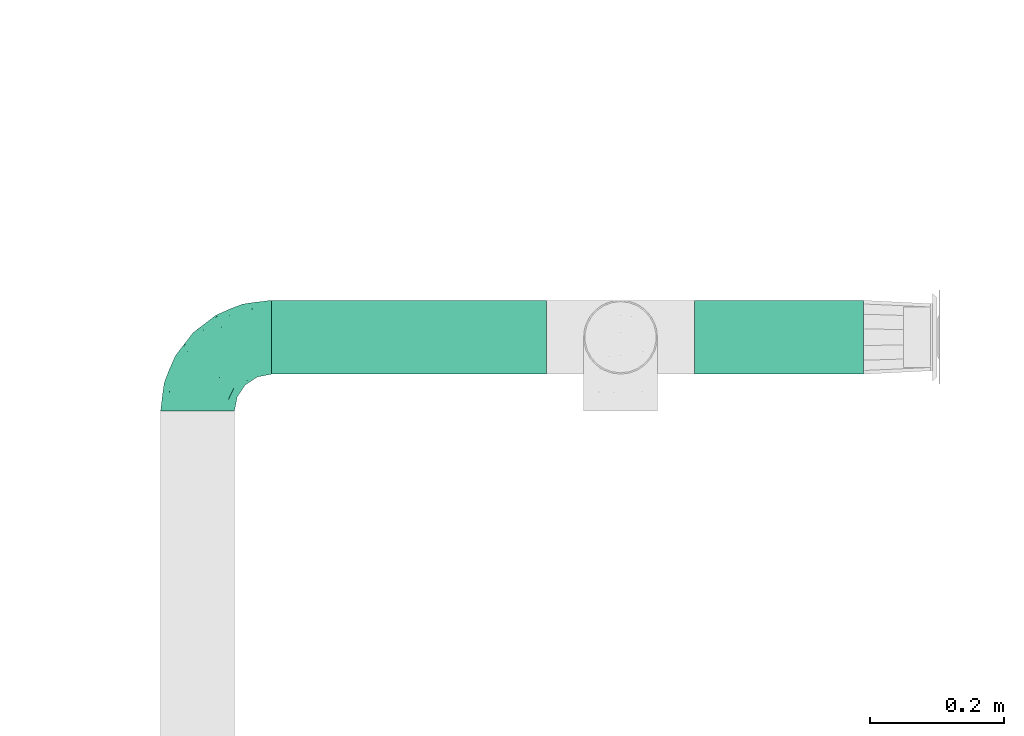
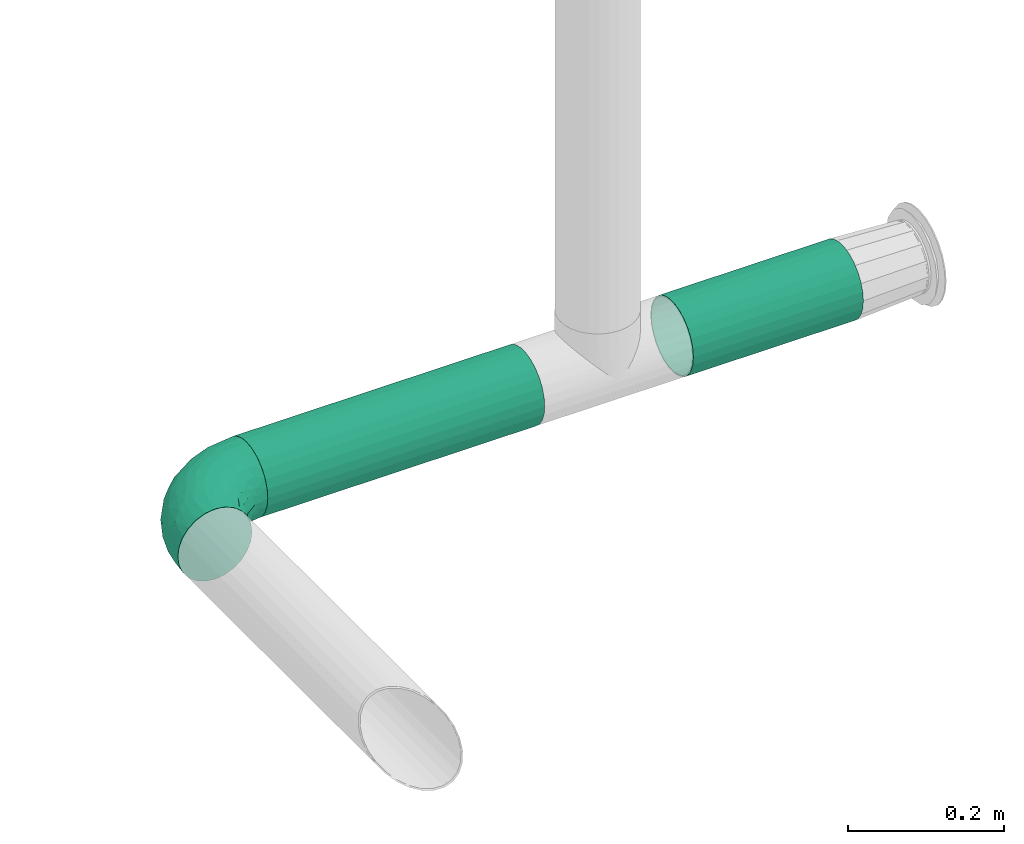
# One storey, part 43 of 103: 2 flow segments, 1 flow fitting.
"""IFC2X3 building model written with IfcOpenShell, lengths in millimetres."""

from ifc_helpers import new_model, entity, si_unit, converted_unit, derived_unit, direction, frame, origin_with_axes, origin_2d_with_axis, place, context, subcontext, project, spatial, hollow_circle, extrude, open_shell, surface_model, source, transform, mapped, material, layer, layer_set, layer_usage, type_object, element, save


model = new_model("IFC2X3")

# Units and contexts
model_context = context("Model", 3, precision=1e-05, world=origin_with_axes(), true_north=direction((0.0, 1.0)))
body_context = subcontext(model_context, "Body", "Model", "MODEL_VIEW")
ifc_project = project(units=[si_unit("AREAUNIT", "SQUARE_METRE"), si_unit("VOLUMEUNIT", "CUBIC_METRE", prefix="DECI"), si_unit("TIMEUNIT", "SECOND"), si_unit("THERMODYNAMICTEMPERATUREUNIT", "DEGREE_CELSIUS"), si_unit("PRESSUREUNIT", "PASCAL"), si_unit("MASSUNIT", "GRAM", prefix="KILO"), si_unit("LENGTHUNIT", "METRE", prefix="MILLI"), si_unit("POWERUNIT", "WATT"), si_unit("ELECTRICCURRENTUNIT", "AMPERE"), si_unit("ELECTRICVOLTAGEUNIT", "VOLT"), derived_unit("VOLUMETRICFLOWRATEUNIT", [(si_unit("VOLUMEUNIT", "CUBIC_METRE", prefix="DECI"), 1), (si_unit("TIMEUNIT", "SECOND"), -1)]), derived_unit("LINEARVELOCITYUNIT", [(si_unit("LENGTHUNIT", "METRE"), 1), (si_unit("TIMEUNIT", "SECOND"), -1)]), derived_unit("MASSDENSITYUNIT", [(si_unit("MASSUNIT", "GRAM", prefix="KILO"), 1), (si_unit("VOLUMEUNIT", "CUBIC_METRE"), -1)]), converted_unit("PLANEANGLEUNIT", "DEGREE", entity("IfcRatioMeasure", 0.01745), si_unit("PLANEANGLEUNIT", "RADIAN"), dimensions=[0, 0, 0, 0, 0, 0, 0])], contexts=[model_context])

# Site, building, storey
site_placement = place(None, origin_with_axes())
site = spatial("IfcSite", under=ifc_project, at=site_placement, CompositionType="ELEMENT")
building_placement = place(site_placement, origin_with_axes())
building = spatial("IfcBuilding", under=site, at=building_placement, Name="mc-building", CompositionType="ELEMENT")
storey_placement = place(building_placement, frame((0.0, 0.0, 5900.0), z_axis=(0.0, 0.0, 1.0), x_axis=(1.0, 0.0, 0.0)))
storey = spatial("IfcBuildingStorey", under=building, at=storey_placement, Name="3. Korrus", CompositionType="ELEMENT", Elevation=5900.0)

# Flow segments
ifc_material = material(Name="FZ1")
ifc_layer = layer(ifc_material, 0.0)
ifc_layer_set = layer_set([ifc_layer], Name="FZ1")
ifc_layer_usage = layer_usage(ifc_layer_set, "AXIS1", "POSITIVE", 0.0)
duct_segment_type = type_object("IfcDuctSegmentType", PredefinedType="RIGIDSEGMENT")
shared_shape_1 = source(origin_with_axes(), body_context, "Body", "SweptSolid", [
    extrude(hollow_circle(Radius=55.0, WallThickness=2.0, at=origin_2d_with_axis()), frame((0.0, 0.0, 0.0), z_axis=(1.0, 0.0, 0.0), x_axis=(0.0, 1.0, 0.0)), (0.0, 0.0, 1.0), 251.8),
])
flow_segment_1_placement = place(storey_placement, frame((12991.59664, 9477.62755, 2345.0), z_axis=(0.0, 0.0, 1.0), x_axis=(1.0, 0.0, 0.0)))
element("IfcFlowSegment", 1, at=flow_segment_1_placement, inside=storey, type_object=duct_segment_type, material=ifc_layer_usage, context=body_context, shape_type="MappedRepresentation", body=[
    mapped(shared_shape_1, transform((0.0, 0.0, 0.0), scale=1.0)),
])
shared_shape_2 = source(origin_with_axes(), body_context, "Body", "SweptSolid", [
    extrude(hollow_circle(Radius=55.0, WallThickness=2.0, at=origin_2d_with_axis()), frame((0.0, 0.0, 0.0), z_axis=(1.0, 0.0, 0.0), x_axis=(0.0, 1.0, 0.0)), (0.0, 0.0, 1.0), 410.1),
])
flow_segment_2_placement = place(storey_placement, frame((12361.54332, 9477.62755, 2345.0), z_axis=(0.0, 0.0, 1.0), x_axis=(1.0, 0.0, 0.0)))
element("IfcFlowSegment", 2, at=flow_segment_2_placement, inside=storey, type_object=duct_segment_type, material=ifc_layer_usage, context=body_context, shape_type="MappedRepresentation", body=[
    mapped(shared_shape_2, transform((0.0, 0.0, 0.0), scale=1.0)),
])

# Flow fitting
duct_fitting_type = type_object("IfcDuctFittingType", Name="BU", PredefinedType="BEND")
shared_shape_3 = source(origin_with_axes(), body_context, "Body", "SurfaceModel", [
    surface_model("IfcShellBasedSurfaceModel", [(-110.0, -38.89087, -38.89087), (-110.0, -55.0, 0.0), (-110.0, -27.5, -47.63139), (-110.0, -53.12592, -14.23505), (-110.0, -47.63139, -27.5), (-110.0, 47.63139, -27.5), (-110.0, 53.12592, 14.23505), (-110.0, 53.12592, -14.23505), (-110.0, -14.23505, -53.12592), (-110.0, 0.0, -55.0), (-110.0, 38.89087, -38.89087), (-110.0, 27.5, -47.63139), (-110.0, 14.23505, -53.12592), (-110.0, 55.0, 0.0), (-110.0, -53.12592, 14.23505), (-110.0, -47.63139, 27.5), (-110.0, -38.89087, 38.89087), (-110.0, 0.0, 55.0), (-110.0, -27.5, 47.63139), (-110.0, -14.23505, 53.12592), (-110.0, 38.89087, 38.89087), (-110.0, 47.63139, 27.5), (-110.0, 27.5, 47.63139), (-110.0, 14.23505, 53.12592), (0.0, -110.0, -55.0), (14.23505, -110.0, -53.12592), (-14.23505, -110.0, -53.12592), (-53.12592, -110.0, 14.23505), (-27.5, -110.0, -47.63139), (-47.63139, -110.0, -27.5), (-38.89087, -110.0, -38.89087), (55.0, -110.0, 0.0), (53.12592, -110.0, 14.23505), (38.89087, -110.0, -38.89087), (27.5, -110.0, -47.63139), (53.12592, -110.0, -14.23505), (47.63139, -110.0, -27.5), (-53.12592, -110.0, -14.23505), (-47.63139, -110.0, 27.5), (-38.89087, -110.0, 38.89087), (14.23505, -110.0, 53.12592), (-27.5, -110.0, 47.63139), (-14.23505, -110.0, 53.12592), (47.63139, -110.0, 27.5), (38.89087, -110.0, 38.89087), (27.5, -110.0, 47.63139), (0.0, -110.0, 55.0), (-55.0, -110.0, 0.0), (-60.44912, -32.56953, 51.94617), (-76.6405, -38.18013, 45.55988), (-64.21732, -48.68956, 43.63444), (-90.15553, -11.94394, 54.09138), (-76.00813, -5.38378, 55.0), (-70.18771, -18.55163, 54.03432), (-78.5998, -26.77405, 50.81338), (-93.27622, -45.77614, 33.48188), (-75.55424, -54.2118, 32.41257), (-96.12334, -22.13664, 50.81337), (-32.04182, -59.64019, 52.24446), (-18.36258, -70.48427, 54.04484), (-21.00813, -45.34362, 55.0), (-63.60674, -66.07878, 29.97482), (-74.66383, -63.08407, 19.92123), (-63.88653, -74.77858, 17.99134), (-93.11138, -56.59448, 10.50359), (-99.597, -52.72185, 18.52927), (-98.21577, -57.34403, 0.0), (-53.42855, -92.60092, 21.04759), (-88.54852, -54.8376, 21.04759), (-5.38378, -76.00813, 55.0), (-11.86161, -90.23965, 54.10313), (-56.64619, -93.12774, 10.22088), (-57.34403, -98.21577, 0.0), (-44.60838, -44.60838, 52.13415), (-45.34362, -21.00813, 55.0), (-92.68484, -35.46673, 43.63443), (-22.25266, -95.40765, 50.81337), (-27.23711, -77.39884, 50.81337), (-43.70931, -69.58671, 44.47149), (-35.97783, -90.61597, 43.63443), (-58.67786, -84.31125, 16.04456), (-57.2828, -79.3123, 24.9774), (-82.93277, -60.36161, 12.91784), (-49.88337, -54.51816, 47.224), (-74.57753, -66.83759, 9.55742), (-45.35812, -94.97281, 33.48188), (-59.18663, -88.95241, 0.0), (-51.517, -78.6292, 33.48188), (-65.14788, -80.03077, 0.0), (-56.45322, -62.06476, 39.63545), (-88.95241, -59.18663, 0.0), (-80.03077, -65.14788, 0.0), (-71.10913, -71.10913, 0.0), (-94.9309, -45.36788, -33.48188), (-93.11358, -56.60141, -10.46614), (-99.64997, -52.79499, -18.30015), (-79.99933, -46.56772, -37.92748), (-90.20425, -36.08686, -43.63443), (-45.34362, -21.00813, -55.0), (-72.75364, -19.68651, -53.60527), (-76.00813, -5.38378, -55.0), (-21.00813, -45.34362, -55.0), (-5.38378, -76.00813, -55.0), (-21.91957, -65.12078, -53.85897), (-35.41876, -92.89265, -43.63443), (-91.10309, -11.02766, -54.21832), (-45.77614, -93.27622, -33.48188), (-90.50474, -23.21022, -50.81337), (-70.92854, -33.31794, -49.51754), (-78.52933, -63.35627, -11.73997), (-24.91508, -84.05606, -50.81337), (-88.78941, -54.74452, -21.04759), (-63.49062, -67.59111, -28.46929), (-73.36422, -62.46673, -22.94182), (-69.59921, -57.34866, -33.48187), (-56.59448, -93.11138, -10.50359), (-54.10679, -75.85581, -32.31867), (-54.8376, -88.54852, -21.04759), (-57.75956, -31.09612, -52.80882), (-52.72185, -99.597, -18.52927), (-12.62913, -89.46304, -53.99097), (-34.46825, -66.46123, -50.04329), (-43.9837, -43.9837, -52.42279), (-65.78527, -72.58348, -17.68796), (-57.47001, -51.99467, -44.91465), (-70.34468, -43.65295, -44.21951), (-60.72547, -82.29174, -12.88567), (-42.34915, -74.24548, -43.63444), (-57.25194, -63.5016, -38.08211), (-80.95344, -53.56991, -29.32027), (-52.32891, -4.55257, -54.0482), (14.95561, -36.05775, -42.26543), (14.88266, -20.92917, -33.7947), (32.52942, -47.13398, -30.48571), (19.3559, -65.35825, -48.00507), (30.24048, -70.09027, -41.7461), (-28.49299, 30.5778, -16.4009), (-47.13398, 32.52942, -30.48571), (-70.35075, 46.44478, -19.5952), (-22.4954, -22.4954, -53.25347), (-4.55257, -52.32891, -54.0482), (-75.47368, 11.22546, -52.60718), (-81.32209, 51.5606, -9.98467), (-70.09027, 30.24048, -41.7461), (-80.81763, 41.84862, -32.14655), (-9.15831, 10.852, -27.8997), (-36.05774, 14.95561, -42.26543), (-65.35825, 19.3559, -48.00507), (3.94376, -43.9333, -50.53315), (11.22546, -75.47368, -52.60718), (-43.9333, 3.94376, -50.53315), (-13.39742, -13.39743, -48.13058), (50.20582, -74.51695, -9.9731), (41.8609, -47.82256, -9.92641), (49.37776, -67.29486, 0.0), (18.93131, -11.7156, -17.56239), (-1.23348, 12.25375, -12.18106), (-27.5, 32.89419, 0.0), (41.84862, -80.81763, -32.14655), (46.44478, -70.35075, -19.5952), (35.70604, -41.31408, -20.38235), (6.67262, 6.67262, 0.0), (32.89419, -27.5, 0.0), (-50.36265, 42.95545, -9.51562), (-67.29486, 49.37776, 0.0), (-5.47251, -5.47251, -39.92906), (-70.35075, 46.44478, 19.5952), (-74.51695, 50.20582, 9.9731), (-47.13398, 32.52942, 30.48571), (-41.31407, 35.70604, 20.38235), (-80.81763, 41.84862, 32.14655), (11.22546, -75.47368, 52.60718), (-4.55257, -52.32891, 54.0482), (-36.05774, 14.95561, 42.26543), (-65.35825, 19.3559, 48.00507), (-43.9333, 3.94376, 50.53315), (-70.09027, 30.24048, 41.7461), (-11.7156, 18.93131, 17.56239), (12.25375, -1.23348, 12.18106), (30.5778, -28.49299, 16.4009), (42.95545, -50.36265, 9.51562), (51.5606, -81.32209, 9.98467), (-52.32891, -4.55257, 54.0482), (-75.47368, 11.22546, 52.60718), (-13.39742, -13.39743, 48.13058), (-22.4954, -22.4954, 53.25347), (3.94376, -43.9333, 50.53315), (-20.92916, 14.88266, 33.79469), (10.852, -9.15831, 27.8997), (-47.82256, 41.8609, 9.92641), (32.52942, -47.13398, 30.48571), (46.44478, -70.35075, 19.5952), (41.84862, -80.81763, 32.14655), (14.95561, -36.05775, 42.26543), (19.3559, -65.35825, 48.00507), (30.24048, -70.09027, 41.7461), (-5.47251, -5.47251, 39.92906)], [open_shell([[[0, 1, 2]], [[3, 1, 4]], [[5, 6, 7]], [[8, 1, 9]], [[2, 1, 8]], [[4, 1, 0]], [[10, 9, 6]], [[9, 10, 11]], [[11, 12, 9]], [[6, 5, 10]], [[7, 6, 13]], [[14, 15, 9]], [[9, 15, 16]], [[17, 16, 18]], [[9, 16, 17]], [[19, 17, 18]], [[9, 20, 21]], [[6, 9, 21]], [[9, 22, 20]], [[23, 22, 9]], [[17, 23, 9]], [[9, 1, 14]], [[24, 25, 26]], [[26, 27, 28]], [[29, 30, 27]], [[28, 27, 30]], [[26, 31, 32]], [[33, 31, 34]], [[25, 34, 31]], [[35, 31, 36]], [[33, 36, 31]], [[31, 26, 25]], [[29, 27, 37]], [[38, 27, 26]], [[39, 38, 26]], [[40, 41, 26]], [[41, 39, 26]], [[40, 42, 41]], [[43, 44, 26]], [[43, 26, 32]], [[44, 45, 26]], [[26, 45, 40]], [[40, 46, 42]], [[47, 37, 27]], [[48, 49, 50]], [[51, 52, 17]], [[48, 53, 54]], [[49, 55, 56]], [[16, 15, 55]], [[18, 57, 19]], [[58, 59, 60]], [[61, 62, 63]], [[64, 65, 14]], [[53, 51, 54]], [[66, 64, 14]], [[27, 38, 67]], [[65, 68, 55]], [[68, 65, 64]], [[69, 59, 70]], [[71, 72, 27]], [[73, 60, 74]], [[55, 49, 75]], [[42, 70, 76]], [[51, 57, 54]], [[77, 78, 79]], [[42, 76, 41]], [[46, 70, 42]], [[55, 68, 56]], [[75, 18, 16]], [[77, 79, 76]], [[80, 67, 81]], [[68, 82, 62]], [[83, 78, 58]], [[82, 84, 62]], [[39, 79, 85]], [[71, 67, 80]], [[72, 71, 86]], [[67, 85, 87]], [[88, 80, 63]], [[39, 41, 79]], [[87, 79, 78]], [[55, 75, 16]], [[50, 89, 83]], [[38, 39, 85]], [[56, 68, 62]], [[61, 87, 89]], [[48, 50, 83]], [[18, 75, 57]], [[54, 75, 49]], [[38, 85, 67]], [[85, 79, 87]], [[56, 62, 61]], [[50, 56, 89]], [[87, 61, 81]], [[90, 64, 66]], [[14, 1, 66]], [[91, 92, 84]], [[82, 90, 91]], [[90, 82, 64]], [[62, 84, 63]], [[84, 82, 91]], [[64, 82, 68]], [[65, 15, 14]], [[15, 65, 55]], [[72, 47, 27]], [[86, 71, 80]], [[67, 71, 27]], [[88, 63, 92]], [[63, 80, 81]], [[63, 81, 61]], [[87, 81, 67]], [[41, 76, 79]], [[70, 59, 77]], [[76, 70, 77]], [[69, 70, 46]], [[77, 59, 58]], [[59, 69, 60]], [[77, 58, 78]], [[73, 58, 60]], [[19, 57, 51]], [[54, 57, 75]], [[19, 51, 17]], [[53, 52, 51]], [[53, 74, 52]], [[73, 74, 48]], [[53, 48, 74]], [[83, 73, 48]], [[73, 83, 58]], [[78, 83, 89]], [[78, 89, 87]], [[61, 89, 56]], [[54, 49, 48]], [[50, 49, 56]], [[88, 86, 80]], [[63, 84, 92]], [[93, 4, 0]], [[66, 94, 90]], [[95, 94, 3]], [[96, 93, 97]], [[98, 99, 100]], [[0, 2, 97]], [[101, 102, 103]], [[104, 28, 30]], [[9, 105, 8]], [[30, 106, 104]], [[107, 105, 99]], [[97, 107, 108]], [[94, 109, 90]], [[2, 8, 107]], [[94, 66, 3]], [[110, 26, 28]], [[94, 111, 109]], [[112, 113, 114]], [[72, 115, 37]], [[116, 106, 117]], [[98, 118, 99]], [[119, 115, 117]], [[115, 119, 37]], [[110, 120, 26]], [[103, 110, 121]], [[117, 106, 119]], [[120, 110, 103]], [[98, 101, 122]], [[117, 123, 116]], [[108, 124, 125]], [[126, 117, 115]], [[30, 29, 106]], [[120, 102, 24]], [[110, 104, 127]], [[97, 125, 96]], [[118, 122, 124]], [[124, 127, 128]], [[93, 0, 97]], [[86, 126, 115]], [[127, 106, 116]], [[129, 113, 111]], [[4, 93, 95]], [[114, 129, 96]], [[28, 104, 110]], [[127, 104, 106]], [[2, 107, 97]], [[108, 107, 99]], [[118, 108, 99]], [[100, 99, 105]], [[128, 112, 114]], [[127, 124, 121]], [[66, 1, 3]], [[91, 90, 109]], [[95, 111, 94]], [[109, 123, 92]], [[114, 113, 129]], [[111, 95, 93]], [[95, 3, 4]], [[86, 115, 72]], [[37, 47, 72]], [[88, 92, 123]], [[123, 117, 126]], [[126, 88, 123]], [[88, 126, 86]], [[119, 29, 37]], [[29, 119, 106]], [[111, 93, 129]], [[124, 114, 125]], [[100, 105, 9]], [[8, 105, 107]], [[108, 118, 124]], [[122, 118, 98]], [[96, 129, 93]], [[109, 111, 113]], [[113, 123, 109]], [[116, 123, 112]], [[113, 112, 123]], [[116, 112, 128]], [[116, 128, 127]], [[124, 128, 114]], [[103, 122, 101]], [[127, 121, 110]], [[121, 122, 103]], [[122, 121, 124]], [[26, 120, 24]], [[102, 120, 103]], [[108, 125, 97]], [[109, 92, 91]], [[96, 125, 114]], [[100, 130, 98]], [[131, 132, 133]], [[134, 135, 34]], [[136, 137, 138]], [[101, 139, 140]], [[9, 141, 100]], [[138, 7, 142]], [[137, 143, 144]], [[142, 7, 13]], [[145, 146, 137]], [[146, 147, 143]], [[5, 138, 144]], [[7, 138, 5]], [[5, 144, 10]], [[140, 148, 149]], [[143, 11, 10]], [[147, 12, 11]], [[100, 141, 130]], [[98, 139, 101]], [[148, 134, 149]], [[139, 150, 151]], [[152, 153, 154]], [[150, 139, 130]], [[25, 24, 149]], [[141, 12, 147]], [[132, 145, 155]], [[156, 136, 157]], [[158, 33, 135]], [[148, 139, 151]], [[36, 33, 158]], [[34, 135, 33]], [[159, 160, 153]], [[160, 159, 133]], [[137, 146, 143]], [[152, 154, 31]], [[137, 136, 145]], [[161, 162, 155]], [[133, 159, 158]], [[134, 148, 131]], [[163, 164, 157]], [[163, 142, 164]], [[102, 101, 140]], [[162, 154, 153]], [[159, 35, 36]], [[155, 156, 161]], [[131, 165, 132]], [[155, 145, 156]], [[98, 130, 139]], [[150, 130, 141]], [[147, 150, 141]], [[9, 12, 141]], [[149, 24, 102]], [[148, 140, 139]], [[140, 149, 102]], [[34, 25, 134]], [[146, 151, 150]], [[143, 147, 11]], [[147, 146, 150]], [[145, 165, 146]], [[25, 149, 134]], [[135, 134, 131]], [[135, 131, 133]], [[151, 165, 131]], [[148, 151, 131]], [[165, 151, 146]], [[160, 133, 132]], [[132, 165, 145]], [[36, 158, 159]], [[133, 158, 135]], [[10, 144, 143]], [[137, 144, 138]], [[162, 153, 155]], [[159, 153, 152]], [[160, 155, 153]], [[155, 160, 132]], [[152, 35, 159]], [[35, 152, 31]], [[136, 138, 163]], [[164, 142, 13]], [[142, 163, 138]], [[136, 163, 157]], [[161, 156, 157]], [[136, 156, 145]], [[166, 6, 21]], [[167, 164, 13]], [[166, 168, 169]], [[170, 168, 166]], [[69, 171, 172]], [[173, 174, 175]], [[174, 176, 22]], [[161, 157, 177]], [[170, 20, 176]], [[21, 20, 170]], [[178, 179, 162]], [[180, 181, 154]], [[182, 175, 183]], [[183, 23, 17]], [[184, 185, 186]], [[74, 185, 182]], [[52, 74, 182]], [[187, 188, 177]], [[166, 169, 189]], [[190, 179, 188]], [[22, 176, 20]], [[180, 154, 162]], [[32, 191, 43]], [[192, 44, 43]], [[43, 191, 192]], [[32, 31, 181]], [[193, 194, 195]], [[194, 40, 45]], [[190, 193, 195]], [[45, 44, 195]], [[69, 46, 171]], [[74, 60, 185]], [[157, 164, 189]], [[167, 189, 164]], [[172, 60, 69]], [[185, 172, 186]], [[173, 187, 168]], [[191, 32, 181]], [[190, 195, 192]], [[179, 190, 191]], [[175, 174, 183]], [[171, 40, 194]], [[188, 193, 190]], [[175, 185, 184]], [[177, 178, 161]], [[173, 196, 187]], [[177, 188, 178]], [[60, 172, 185]], [[186, 172, 171]], [[194, 186, 171]], [[46, 40, 171]], [[183, 17, 52]], [[175, 182, 185]], [[182, 183, 52]], [[22, 23, 174]], [[193, 184, 186]], [[195, 194, 45]], [[194, 193, 186]], [[188, 196, 193]], [[23, 183, 174]], [[176, 174, 173]], [[176, 173, 168]], [[184, 196, 173]], [[175, 184, 173]], [[196, 184, 193]], [[169, 168, 187]], [[187, 196, 188]], [[21, 170, 166]], [[168, 170, 176]], [[44, 192, 195]], [[190, 192, 191]], [[157, 189, 177]], [[166, 189, 167]], [[169, 177, 189]], [[177, 169, 187]], [[167, 6, 166]], [[6, 167, 13]], [[179, 191, 180]], [[154, 181, 31]], [[181, 180, 191]], [[179, 180, 162]], [[161, 178, 162]], [[179, 178, 188]]])]),
])
flow_fitting_placement = place(storey_placement, frame((12251.54332, 9477.62755, 2345.0), z_axis=(0.0, 0.0, 1.0), x_axis=(0.0, 1.0, 0.0)))
element("IfcFlowFitting", 3, at=flow_fitting_placement, inside=storey, type_object=duct_fitting_type, Name="BU", context=body_context, shape_type="MappedRepresentation", body=[
    mapped(shared_shape_3, transform((0.0, 0.0, 0.0), scale=1.0)),
])

save(model, "model.ifc")
